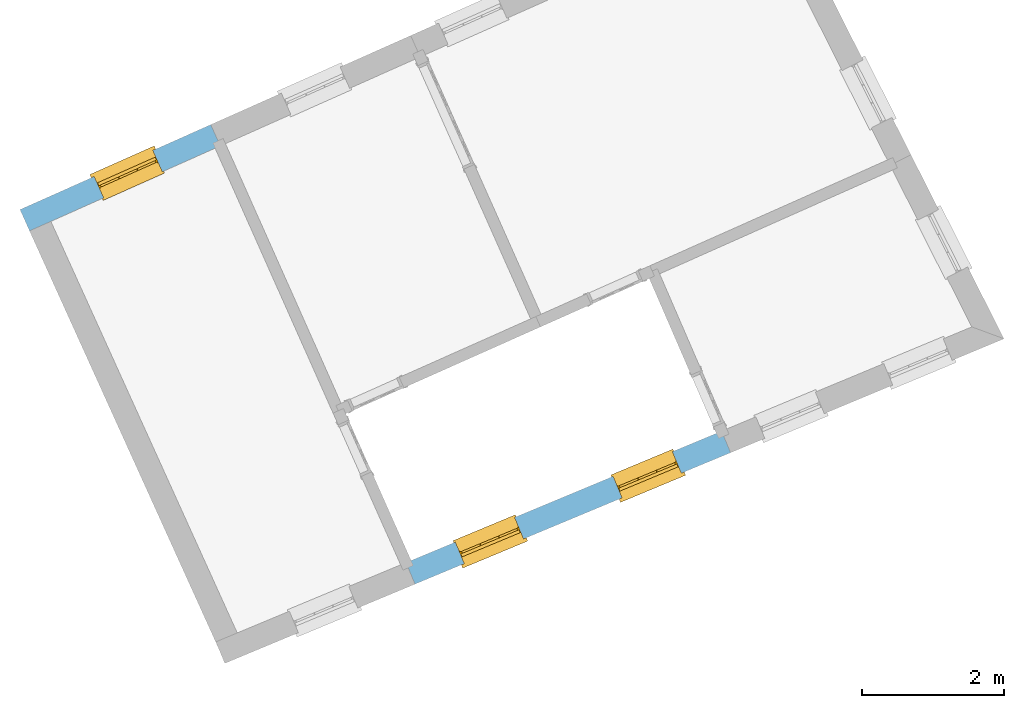
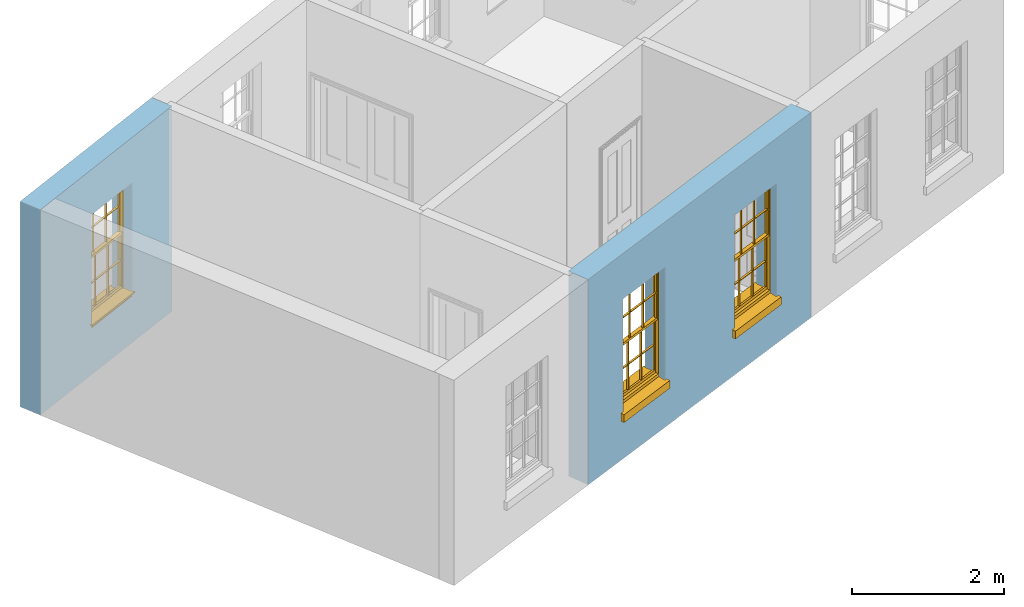
# One storey, part 3 of 8: 3 windows, 3 openings, plus 2 elements that do not belong to this part.
"""IFC2X3 building model written with IfcOpenShell, lengths in metres."""

from ifc_helpers import new_model, si_unit, frame, origin, place, context, subcontext, project, spatial, polyline, outline, extrude, faceted_brep, material, layer, layer_set, layer_usage, element, fill, save


model = new_model("IFC2X3")

# Units and contexts
model_context = context("Model", 3, world=origin())
body_context = subcontext(model_context, "Body", "Model", "MODEL_VIEW")
ifc_project = project(units=[si_unit("PLANEANGLEUNIT", "RADIAN"), si_unit("MASSUNIT", "GRAM", prefix="KILO"), si_unit("FORCEUNIT", "NEWTON", prefix="KILO"), si_unit("LENGTHUNIT", "METRE")], contexts=[model_context])

# Site, building, storey
site_placement = place(None, origin())
site = spatial("IfcSite", under=ifc_project, at=site_placement, CompositionType="ELEMENT")
building_placement = place(None, origin())
building = spatial("IfcBuilding", under=site, at=building_placement, Name="Building plot-1", CompositionType="ELEMENT")
storey_placement = place(None, frame((0.0, 0.0, 5.15)))
storey = spatial("IfcBuildingStorey", under=building, at=storey_placement, Name="Floor 1", CompositionType="ELEMENT", Elevation=5.15)

# Wall, openings, windows
ifc_material = material(Name="Masonry")
ifc_layer = layer(ifc_material, 0.33, ventilated=False)
ifc_layer_set = layer_set([ifc_layer], Name="My Wall")
ifc_layer_usage = layer_usage(ifc_layer_set, "AXIS2", "NEGATIVE", 0.08)
wall_1_placement = place(storey_placement, origin())
wall_1 = element("IfcWallStandardCase", 1, at=wall_1_placement, inside=storey, material=ifc_layer_usage, Name="exterior", context=body_context, shape_type="SweptSolid", body=[
    extrude(outline(polyline([(24.2430798056257, 41.3933128508107), (24.3699915253352, 41.0886927342715), (28.8304515653399, 42.947022580652), (28.7035398456304, 43.2516426971912), (24.2430798056257, 41.3933128508107)])), origin(), (0.0, 0.0, 1.0), 3.3),
])
opening_1_placement = place(storey_placement, frame((0.0, 0.0, 0.75)))
opening_1 = element("IfcOpeningElement", 2, at=opening_1_placement, cuts=wall_1, Name="Opening", ObjectType="Opening", context=body_context, shape_type="SweptSolid", body=[
    extrude(outline(polyline([(25.0651000110172, 41.378290855055), (25.9051130596556, 41.7282595366783), (25.7782013399461, 42.0328796532175), (24.9381882913076, 41.6829109715942), (25.0651000110172, 41.378290855055)])), origin(), (0.0, 0.0, 1.0), 1.82),
])
opening_2_placement = place(storey_placement, frame((0.0, 0.0, 0.75)))
opening_2 = element("IfcOpeningElement", 3, at=opening_2_placement, cuts=wall_1, Name="Opening", ObjectType="Opening", context=body_context, shape_type="SweptSolid", body=[
    extrude(outline(polyline([(27.2953300310195, 42.3074557782452), (28.135343079658, 42.6574244598685), (28.0084313599484, 42.9620445764077), (27.16841831131, 42.6120758947844), (27.2953300310195, 42.3074557782452)])), origin(), (0.0, 0.0, 1.0), 1.82),
])
window_1_placement = place(storey_placement, frame((24.968954768813, 41.609063670615, 0.75), z_axis=(0.0, 0.0, 1.0), x_axis=(0.84001304863844, 0.349968681623302, 0.0)))
window_1 = element("IfcWindow", 4, at=window_1_placement, inside=storey, Name="circulation outside window", OverallHeight=1.82, OverallWidth=0.91, context=body_context, shape_type="Brep", held_by="IfcProductRepresentation", body=[
    faceted_brep([(0.033125, -0.105, 0.975209), (0.01, -0.105, 0.975209), (0.033125, -0.105, 1.376042), (0.876875, -0.105, 0.975209), (0.876875, -0.105, 1.376042), (0.9, -0.105, 0.975209), (0.876875, -0.105, 1.386042), (0.876875, -0.105, 1.786875), (0.9, -0.105, 1.81), (0.033125, -0.105, 1.786875), (0.033125, -0.105, 1.386042), (0.01, -0.105, 1.81), (0.876875, -0.135, 1.376042), (0.876875, -0.135, 0.975209), (0.9, -0.135, 0.937083), (0.033125, -0.135, 1.786875), (0.01, -0.135, 1.81), (0.033125, -0.135, 1.386042), (0.01, -0.135, 0.937083), (0.033125, -0.135, 0.975209), (0.033125, -0.135, 1.376042), (0.876875, -0.135, 1.786875), (0.876875, -0.135, 1.386042), (0.9, -0.135, 1.81), (0.033125, -0.105, 0.937083), (0.01, -0.105, 0.937083), (0.033125, -0.105, 0.53625), (0.876875, -0.105, 0.937083), (0.876875, -0.105, 0.53625), (0.9, -0.105, 0.937083), (0.876875, -0.105, 0.52625), (0.876875, -0.105, 0.125417), (0.9, -0.105, 0.077167), (0.033125, -0.105, 0.125417), (0.033125, -0.105, 0.52625), (0.01, -0.105, 0.077167), (-0.0425, -0.25, 0.01), (-0.0425, -0.3, 0.001667), (0.0, -0.25, 0.01), (0.9525, -0.25, 0.01), (0.91, -0.25, 0.01), (0.9525, -0.3, 0.001667), (-0.02, 0.08, 0.077167), (0.0, 0.08, 0.077167), (-0.02, 0.11, 0.077167), (0.0, -0.06, 0.077167), (0.01, -0.06, 0.077167), (0.91, -0.06, 0.077167), (0.91, 0.08, 0.077167), (0.9, -0.06, 0.077167), (0.93, 0.08, 0.077167), (0.93, 0.11, 0.077167), (0.01, -0.075, 0.975209), (0.9, -0.075, 0.975209), (0.876875, -0.075, 0.125417), (0.876875, -0.075, 0.52625), (0.9, -0.075, 0.077167), (0.876875, -0.075, 0.53625), (0.876875, -0.075, 0.937083), (0.033125, -0.075, 0.125417), (0.01, -0.075, 0.077167), (0.033125, -0.075, 0.52625), (0.033125, -0.075, 0.937083), (0.033125, -0.075, 0.53625), (-0.02, 0.08, 0.052167), (-0.02, 0.11, 0.052167), (0.93, 0.11, 0.052167), (0.93, 0.08, 0.052167), (0.91, 0.08, 0.052167), (0.0, 0.08, 0.052167), (0.91, -0.15, 0.026667), (0.0, -0.15, 0.026667), (-0.0425, -0.3, -0.123333), (0.9525, -0.3, -0.123333), (-0.0425, -0.25, -0.123333), (0.9525, -0.25, -0.123333), (0.01, -0.06, 1.81), (0.9, -0.06, 1.81), (0.0, -0.06, 1.82), (0.91, -0.06, 1.82), (0.01, -0.15, 0.077167), (0.9, -0.15, 0.077167), (0.592292, -0.105, 0.125417), (0.592292, -0.075, 0.125417), (0.317708, -0.075, 0.125417), (0.317708, -0.105, 0.125417), (0.592292, -0.105, 0.53625), (0.317708, -0.105, 0.53625), (0.317708, -0.105, 0.52625), (0.592292, -0.105, 0.52625), (0.592292, -0.075, 0.53625), (0.317708, -0.075, 0.53625), (0.592292, -0.135, 1.386042), (0.592292, -0.105, 1.386042), (0.317708, -0.105, 1.386042), (0.317708, -0.135, 1.386042), (0.317708, -0.135, 1.376042), (0.592292, -0.135, 1.376042), (0.317708, -0.105, 1.376042), (0.592292, -0.105, 1.376042), (0.602292, -0.135, 1.376042), (0.592292, -0.135, 0.975209), (0.602292, -0.135, 0.975209), (0.602292, -0.105, 0.975209), (0.592292, -0.105, 0.975209), (0.602292, -0.105, 1.376042), (0.602292, -0.075, 0.53625), (0.602292, -0.105, 0.53625), (0.317708, -0.075, 0.52625), (0.307708, -0.075, 0.125417), (0.307708, -0.075, 0.52625), (0.602292, -0.075, 0.52625), (0.602292, -0.075, 0.125417), (0.592292, -0.075, 0.52625), (0.307708, -0.075, 0.53625), (0.317708, -0.075, 0.937083), (0.307708, -0.075, 0.937083), (0.602292, -0.075, 0.937083), (0.592292, -0.075, 0.937083), (0.307708, -0.105, 0.52625), (0.307708, -0.105, 0.125417), (0.307708, -0.105, 0.53625), (0.307708, -0.105, 0.937083), (0.592292, -0.105, 0.937083), (0.317708, -0.105, 0.937083), (0.602292, -0.105, 0.937083), (0.602292, -0.105, 0.52625), (0.602292, -0.105, 0.125417), (0.307708, -0.135, 1.386042), (0.307708, -0.135, 1.376042), (0.307708, -0.135, 0.975209), (0.317708, -0.135, 0.975209), (0.317708, -0.135, 1.786875), (0.307708, -0.135, 1.786875), (0.602292, -0.135, 1.786875), (0.592292, -0.135, 1.786875), (0.602292, -0.135, 1.386042), (0.602292, -0.105, 1.386042), (0.307708, -0.105, 1.386042), (0.307708, -0.105, 1.786875), (0.317708, -0.105, 1.786875), (0.592292, -0.105, 1.786875), (0.602292, -0.105, 1.786875), (0.307708, -0.105, 1.376042), (0.317708, -0.105, 0.975209), (0.307708, -0.105, 0.975209), (0.91, -0.15, 1.82), (0.9, -0.15, 1.81), (0.01, -0.15, 1.81), (0.0, -0.15, 1.82), (0.91, -0.25, 0.0), (0.0, -0.25, 0.0), (0.91, 0.08, 0.0), (0.0, 0.08, 0.0)], [[[0, 1, 2]], [[3, 4, 5]], [[6, 7, 8]], [[9, 10, 11]], [[12, 13, 14]], [[15, 16, 17]], [[18, 19, 20]], [[21, 22, 23]], [[24, 25, 26]], [[27, 28, 29]], [[30, 31, 32]], [[33, 34, 35]], [[14, 27, 29]], [[25, 24, 18]], [[36, 37, 38]], [[39, 40, 41]], [[42, 43, 44]], [[45, 46, 43]], [[47, 48, 49]], [[50, 51, 48]], [[1, 0, 52]], [[5, 53, 3]], [[54, 55, 56]], [[57, 58, 53]], [[59, 60, 61]], [[62, 63, 52]], [[48, 43, 46, 49]], [[51, 44, 43, 48]], [[64, 42, 44, 65]], [[65, 44, 51, 66]], [[66, 51, 50, 67]], [[65, 66, 68, 69]], [[60, 56, 49, 46]], [[70, 71, 38, 40]], [[37, 41, 40, 38]], [[37, 72, 73, 41]], [[74, 75, 73, 72]], [[8, 11, 76, 77]], [[76, 78, 79, 77]], [[32, 35, 80, 81]], [[81, 80, 71, 70]], [[82, 83, 84, 85]], [[86, 87, 88, 89]], [[86, 90, 91, 87]], [[92, 93, 94, 95]], [[92, 95, 96, 97]], [[96, 98, 99, 97]], [[100, 97, 101, 102]], [[103, 104, 99, 105]], [[97, 99, 104, 101]], [[102, 103, 105, 100]], [[28, 57, 106, 107]], [[108, 84, 109, 110]], [[111, 112, 83, 113]], [[114, 110, 61, 63]], [[90, 113, 108, 91]], [[115, 91, 114, 116]], [[117, 106, 90, 118]], [[111, 106, 57, 55]], [[119, 110, 109, 120]], [[34, 61, 110, 119]], [[89, 113, 83, 82]], [[88, 108, 113, 89]], [[85, 84, 108, 88]], [[121, 114, 63, 26]], [[122, 116, 114, 121]], [[123, 118, 90, 86]], [[87, 91, 115, 124]], [[107, 106, 117, 125]], [[126, 111, 55, 30]], [[127, 112, 111, 126]], [[126, 30, 28, 107]], [[88, 119, 120, 85]], [[126, 89, 82, 127]], [[125, 123, 86, 107]], [[121, 26, 34, 119]], [[124, 122, 121, 87]], [[128, 17, 20, 129]], [[96, 129, 130, 131]], [[132, 133, 128, 95]], [[134, 135, 92, 136]], [[100, 12, 22, 136]], [[137, 6, 4, 105]], [[94, 138, 139, 140]], [[137, 93, 141, 142]], [[99, 98, 94, 93]], [[143, 2, 10, 138]], [[144, 145, 143, 98]], [[129, 143, 145, 130]], [[20, 2, 143, 129]], [[131, 144, 98, 96]], [[128, 138, 10, 17]], [[133, 139, 138, 128]], [[135, 141, 93, 92]], [[95, 94, 140, 132]], [[22, 6, 137, 136]], [[136, 137, 142, 134]], [[100, 105, 4, 12]], [[107, 86, 89, 126]], [[106, 111, 113, 90]], [[91, 108, 110, 114]], [[87, 121, 119, 88]], [[97, 100, 136, 92]], [[129, 96, 95, 128]], [[98, 143, 138, 94]], [[105, 99, 93, 137]], [[131, 101, 104, 144]], [[124, 115, 118, 123]], [[132, 140, 141, 135]], [[120, 109, 59, 33]], [[15, 9, 139, 133]], [[134, 142, 7, 21]], [[31, 54, 112, 127]], [[36, 74, 72, 37]], [[39, 41, 73, 75]], [[18, 14, 101, 131]], [[23, 16, 132, 135]], [[83, 56, 60, 84]], [[52, 53, 118, 115]], [[53, 52, 144, 104]], [[11, 8, 141, 140]], [[14, 18, 124, 123]], [[2, 1, 11, 10]], [[8, 5, 4, 6]], [[57, 53, 56, 55]], [[60, 52, 63, 61]], [[26, 25, 35, 34]], [[32, 29, 28, 30]], [[14, 23, 22, 12]], [[18, 20, 17, 16]], [[19, 0, 2, 20]], [[17, 10, 9, 15]], [[12, 4, 3, 13]], [[21, 7, 6, 22]], [[27, 58, 57, 28]], [[30, 55, 54, 31]], [[33, 59, 61, 34]], [[26, 63, 62, 24]], [[5, 8, 77, 53]], [[76, 11, 1, 52]], [[46, 45, 78, 76]], [[49, 77, 79, 47]], [[70, 146, 147, 81]], [[71, 80, 148, 149]], [[19, 130, 145, 0]], [[102, 13, 3, 103]], [[116, 122, 24, 62]], [[29, 32, 81, 14]], [[80, 35, 25, 18]], [[60, 46, 76, 52]], [[77, 49, 56, 53]], [[23, 14, 81, 147]], [[16, 148, 80, 18]], [[35, 85, 120]], [[120, 33, 35]], [[127, 82, 32]], [[32, 31, 127]], [[32, 82, 85, 35]], [[102, 101, 14]], [[14, 13, 102]], [[18, 131, 130]], [[130, 19, 18]], [[134, 21, 23]], [[23, 135, 134]], [[16, 15, 133]], [[133, 132, 16]], [[11, 140, 139]], [[139, 9, 11]], [[142, 141, 8]], [[8, 7, 142]], [[23, 147, 148, 16]], [[146, 149, 148, 147]], [[52, 115, 116]], [[116, 62, 52]], [[118, 53, 117]], [[58, 117, 53]], [[27, 125, 117, 58]], [[56, 83, 112]], [[112, 54, 56]], [[109, 84, 60]], [[60, 59, 109]], [[125, 27, 14]], [[14, 123, 125]], [[122, 124, 18]], [[18, 24, 122]], [[145, 144, 52]], [[52, 0, 145]], [[103, 3, 53]], [[53, 104, 103]], [[79, 78, 149, 146]], [[78, 45, 71, 149]], [[146, 70, 47, 79]], [[150, 75, 74, 151]], [[68, 66, 67]], [[48, 68, 67, 50]], [[69, 64, 65]], [[42, 64, 69, 43]], [[69, 68, 152, 153]], [[70, 68, 48, 47]], [[150, 152, 68, 70]], [[43, 69, 71, 45]], [[69, 153, 151, 71]], [[152, 150, 151, 153]], [[38, 151, 74, 36]], [[71, 151, 38]], [[39, 75, 150, 40]], [[40, 150, 70]]]),
])
fill(opening_1, window_1)
window_2_placement = place(storey_placement, frame((27.1991847888153, 42.5382285938052, 0.75), z_axis=(0.0, 0.0, 1.0), x_axis=(0.84001304863844, 0.349968681623302, 0.0)))
window_2 = element("IfcWindow", 5, at=window_2_placement, inside=storey, Name="circulation outside window", OverallHeight=1.82, OverallWidth=0.91, context=body_context, shape_type="Brep", held_by="IfcProductRepresentation", body=[
    faceted_brep([(0.033125, -0.105, 0.975209), (0.01, -0.105, 0.975209), (0.033125, -0.105, 1.376042), (0.876875, -0.105, 0.975209), (0.876875, -0.105, 1.376042), (0.9, -0.105, 0.975209), (0.876875, -0.105, 1.386042), (0.876875, -0.105, 1.786875), (0.9, -0.105, 1.81), (0.033125, -0.105, 1.786875), (0.033125, -0.105, 1.386042), (0.01, -0.105, 1.81), (0.876875, -0.135, 1.376042), (0.876875, -0.135, 0.975209), (0.9, -0.135, 0.937083), (0.033125, -0.135, 1.786875), (0.01, -0.135, 1.81), (0.033125, -0.135, 1.386042), (0.01, -0.135, 0.937083), (0.033125, -0.135, 0.975209), (0.033125, -0.135, 1.376042), (0.876875, -0.135, 1.786875), (0.876875, -0.135, 1.386042), (0.9, -0.135, 1.81), (0.033125, -0.105, 0.937083), (0.01, -0.105, 0.937083), (0.033125, -0.105, 0.53625), (0.876875, -0.105, 0.937083), (0.876875, -0.105, 0.53625), (0.9, -0.105, 0.937083), (0.876875, -0.105, 0.52625), (0.876875, -0.105, 0.125417), (0.9, -0.105, 0.077167), (0.033125, -0.105, 0.125417), (0.033125, -0.105, 0.52625), (0.01, -0.105, 0.077167), (-0.0425, -0.25, 0.01), (-0.0425, -0.3, 0.001667), (0.0, -0.25, 0.01), (0.9525, -0.25, 0.01), (0.91, -0.25, 0.01), (0.9525, -0.3, 0.001667), (-0.02, 0.08, 0.077167), (0.0, 0.08, 0.077167), (-0.02, 0.11, 0.077167), (0.0, -0.06, 0.077167), (0.01, -0.06, 0.077167), (0.91, -0.06, 0.077167), (0.91, 0.08, 0.077167), (0.9, -0.06, 0.077167), (0.93, 0.08, 0.077167), (0.93, 0.11, 0.077167), (0.01, -0.075, 0.975209), (0.9, -0.075, 0.975209), (0.876875, -0.075, 0.125417), (0.876875, -0.075, 0.52625), (0.9, -0.075, 0.077167), (0.876875, -0.075, 0.53625), (0.876875, -0.075, 0.937083), (0.033125, -0.075, 0.125417), (0.01, -0.075, 0.077167), (0.033125, -0.075, 0.52625), (0.033125, -0.075, 0.937083), (0.033125, -0.075, 0.53625), (-0.02, 0.08, 0.052167), (-0.02, 0.11, 0.052167), (0.93, 0.11, 0.052167), (0.93, 0.08, 0.052167), (0.91, 0.08, 0.052167), (0.0, 0.08, 0.052167), (0.91, -0.15, 0.026667), (0.0, -0.15, 0.026667), (-0.0425, -0.3, -0.123333), (0.9525, -0.3, -0.123333), (-0.0425, -0.25, -0.123333), (0.9525, -0.25, -0.123333), (0.01, -0.06, 1.81), (0.9, -0.06, 1.81), (0.0, -0.06, 1.82), (0.91, -0.06, 1.82), (0.01, -0.15, 0.077167), (0.9, -0.15, 0.077167), (0.592292, -0.105, 0.125417), (0.592292, -0.075, 0.125417), (0.317708, -0.075, 0.125417), (0.317708, -0.105, 0.125417), (0.592292, -0.105, 0.53625), (0.317708, -0.105, 0.53625), (0.317708, -0.105, 0.52625), (0.592292, -0.105, 0.52625), (0.592292, -0.075, 0.53625), (0.317708, -0.075, 0.53625), (0.592292, -0.135, 1.386042), (0.592292, -0.105, 1.386042), (0.317708, -0.105, 1.386042), (0.317708, -0.135, 1.386042), (0.317708, -0.135, 1.376042), (0.592292, -0.135, 1.376042), (0.317708, -0.105, 1.376042), (0.592292, -0.105, 1.376042), (0.602292, -0.135, 1.376042), (0.592292, -0.135, 0.975209), (0.602292, -0.135, 0.975209), (0.602292, -0.105, 0.975209), (0.592292, -0.105, 0.975209), (0.602292, -0.105, 1.376042), (0.602292, -0.075, 0.53625), (0.602292, -0.105, 0.53625), (0.317708, -0.075, 0.52625), (0.307708, -0.075, 0.125417), (0.307708, -0.075, 0.52625), (0.602292, -0.075, 0.52625), (0.602292, -0.075, 0.125417), (0.592292, -0.075, 0.52625), (0.307708, -0.075, 0.53625), (0.317708, -0.075, 0.937083), (0.307708, -0.075, 0.937083), (0.602292, -0.075, 0.937083), (0.592292, -0.075, 0.937083), (0.307708, -0.105, 0.52625), (0.307708, -0.105, 0.125417), (0.307708, -0.105, 0.53625), (0.307708, -0.105, 0.937083), (0.592292, -0.105, 0.937083), (0.317708, -0.105, 0.937083), (0.602292, -0.105, 0.937083), (0.602292, -0.105, 0.52625), (0.602292, -0.105, 0.125417), (0.307708, -0.135, 1.386042), (0.307708, -0.135, 1.376042), (0.307708, -0.135, 0.975209), (0.317708, -0.135, 0.975209), (0.317708, -0.135, 1.786875), (0.307708, -0.135, 1.786875), (0.602292, -0.135, 1.786875), (0.592292, -0.135, 1.786875), (0.602292, -0.135, 1.386042), (0.602292, -0.105, 1.386042), (0.307708, -0.105, 1.386042), (0.307708, -0.105, 1.786875), (0.317708, -0.105, 1.786875), (0.592292, -0.105, 1.786875), (0.602292, -0.105, 1.786875), (0.307708, -0.105, 1.376042), (0.317708, -0.105, 0.975209), (0.307708, -0.105, 0.975209), (0.91, -0.15, 1.82), (0.9, -0.15, 1.81), (0.01, -0.15, 1.81), (0.0, -0.15, 1.82), (0.91, -0.25, 0.0), (0.0, -0.25, 0.0), (0.91, 0.08, 0.0), (0.0, 0.08, 0.0)], [[[0, 1, 2]], [[3, 4, 5]], [[6, 7, 8]], [[9, 10, 11]], [[12, 13, 14]], [[15, 16, 17]], [[18, 19, 20]], [[21, 22, 23]], [[24, 25, 26]], [[27, 28, 29]], [[30, 31, 32]], [[33, 34, 35]], [[14, 27, 29]], [[25, 24, 18]], [[36, 37, 38]], [[39, 40, 41]], [[42, 43, 44]], [[45, 46, 43]], [[47, 48, 49]], [[50, 51, 48]], [[1, 0, 52]], [[5, 53, 3]], [[54, 55, 56]], [[57, 58, 53]], [[59, 60, 61]], [[62, 63, 52]], [[48, 43, 46, 49]], [[51, 44, 43, 48]], [[64, 42, 44, 65]], [[65, 44, 51, 66]], [[66, 51, 50, 67]], [[65, 66, 68, 69]], [[60, 56, 49, 46]], [[70, 71, 38, 40]], [[37, 41, 40, 38]], [[37, 72, 73, 41]], [[74, 75, 73, 72]], [[8, 11, 76, 77]], [[76, 78, 79, 77]], [[32, 35, 80, 81]], [[81, 80, 71, 70]], [[82, 83, 84, 85]], [[86, 87, 88, 89]], [[86, 90, 91, 87]], [[92, 93, 94, 95]], [[92, 95, 96, 97]], [[96, 98, 99, 97]], [[100, 97, 101, 102]], [[103, 104, 99, 105]], [[97, 99, 104, 101]], [[102, 103, 105, 100]], [[28, 57, 106, 107]], [[108, 84, 109, 110]], [[111, 112, 83, 113]], [[114, 110, 61, 63]], [[90, 113, 108, 91]], [[115, 91, 114, 116]], [[117, 106, 90, 118]], [[111, 106, 57, 55]], [[119, 110, 109, 120]], [[34, 61, 110, 119]], [[89, 113, 83, 82]], [[88, 108, 113, 89]], [[85, 84, 108, 88]], [[121, 114, 63, 26]], [[122, 116, 114, 121]], [[123, 118, 90, 86]], [[87, 91, 115, 124]], [[107, 106, 117, 125]], [[126, 111, 55, 30]], [[127, 112, 111, 126]], [[126, 30, 28, 107]], [[88, 119, 120, 85]], [[126, 89, 82, 127]], [[125, 123, 86, 107]], [[121, 26, 34, 119]], [[124, 122, 121, 87]], [[128, 17, 20, 129]], [[96, 129, 130, 131]], [[132, 133, 128, 95]], [[134, 135, 92, 136]], [[100, 12, 22, 136]], [[137, 6, 4, 105]], [[94, 138, 139, 140]], [[137, 93, 141, 142]], [[99, 98, 94, 93]], [[143, 2, 10, 138]], [[144, 145, 143, 98]], [[129, 143, 145, 130]], [[20, 2, 143, 129]], [[131, 144, 98, 96]], [[128, 138, 10, 17]], [[133, 139, 138, 128]], [[135, 141, 93, 92]], [[95, 94, 140, 132]], [[22, 6, 137, 136]], [[136, 137, 142, 134]], [[100, 105, 4, 12]], [[107, 86, 89, 126]], [[106, 111, 113, 90]], [[91, 108, 110, 114]], [[87, 121, 119, 88]], [[97, 100, 136, 92]], [[129, 96, 95, 128]], [[98, 143, 138, 94]], [[105, 99, 93, 137]], [[131, 101, 104, 144]], [[124, 115, 118, 123]], [[132, 140, 141, 135]], [[120, 109, 59, 33]], [[15, 9, 139, 133]], [[134, 142, 7, 21]], [[31, 54, 112, 127]], [[36, 74, 72, 37]], [[39, 41, 73, 75]], [[18, 14, 101, 131]], [[23, 16, 132, 135]], [[83, 56, 60, 84]], [[52, 53, 118, 115]], [[53, 52, 144, 104]], [[11, 8, 141, 140]], [[14, 18, 124, 123]], [[2, 1, 11, 10]], [[8, 5, 4, 6]], [[57, 53, 56, 55]], [[60, 52, 63, 61]], [[26, 25, 35, 34]], [[32, 29, 28, 30]], [[14, 23, 22, 12]], [[18, 20, 17, 16]], [[19, 0, 2, 20]], [[17, 10, 9, 15]], [[12, 4, 3, 13]], [[21, 7, 6, 22]], [[27, 58, 57, 28]], [[30, 55, 54, 31]], [[33, 59, 61, 34]], [[26, 63, 62, 24]], [[5, 8, 77, 53]], [[76, 11, 1, 52]], [[46, 45, 78, 76]], [[49, 77, 79, 47]], [[70, 146, 147, 81]], [[71, 80, 148, 149]], [[19, 130, 145, 0]], [[102, 13, 3, 103]], [[116, 122, 24, 62]], [[29, 32, 81, 14]], [[80, 35, 25, 18]], [[60, 46, 76, 52]], [[77, 49, 56, 53]], [[23, 14, 81, 147]], [[16, 148, 80, 18]], [[35, 85, 120]], [[120, 33, 35]], [[127, 82, 32]], [[32, 31, 127]], [[32, 82, 85, 35]], [[102, 101, 14]], [[14, 13, 102]], [[18, 131, 130]], [[130, 19, 18]], [[134, 21, 23]], [[23, 135, 134]], [[16, 15, 133]], [[133, 132, 16]], [[11, 140, 139]], [[139, 9, 11]], [[142, 141, 8]], [[8, 7, 142]], [[23, 147, 148, 16]], [[146, 149, 148, 147]], [[52, 115, 116]], [[116, 62, 52]], [[118, 53, 117]], [[58, 117, 53]], [[27, 125, 117, 58]], [[56, 83, 112]], [[112, 54, 56]], [[109, 84, 60]], [[60, 59, 109]], [[125, 27, 14]], [[14, 123, 125]], [[122, 124, 18]], [[18, 24, 122]], [[145, 144, 52]], [[52, 0, 145]], [[103, 3, 53]], [[53, 104, 103]], [[79, 78, 149, 146]], [[78, 45, 71, 149]], [[146, 70, 47, 79]], [[150, 75, 74, 151]], [[68, 66, 67]], [[48, 68, 67, 50]], [[69, 64, 65]], [[42, 64, 69, 43]], [[69, 68, 152, 153]], [[70, 68, 48, 47]], [[150, 152, 68, 70]], [[43, 69, 71, 45]], [[69, 153, 151, 71]], [[152, 150, 151, 153]], [[38, 151, 74, 36]], [[71, 151, 38]], [[39, 75, 150, 40]], [[40, 150, 70]]]),
])
fill(opening_2, window_2)

# Wall, opening, window
wall_2_placement = place(storey_placement, origin())
wall_2 = element("IfcWallStandardCase", 6, at=wall_2_placement, inside=storey, material=ifc_layer_usage, Name="exterior", context=body_context, shape_type="SweptSolid", body=[
    extrude(outline(polyline([(21.6184925194357, 47.2817904729088), (21.4842375416494, 47.5832462755393), (18.7880965575994, 46.3825052555824), (18.9223515353857, 46.0810494529519), (21.6184925194357, 47.2817904729088)])), origin(), (0.0, 0.0, 1.0), 3.3),
])
opening_3_placement = place(storey_placement, frame((0.0, 0.0, 0.75)))
opening_3 = element("IfcOpeningElement", 7, at=opening_3_placement, cuts=wall_2, Name="Opening", ObjectType="Opening", context=body_context, shape_type="SweptSolid", body=[
    extrude(outline(polyline([(20.6659984603083, 47.218839059852), (19.8347112469939, 46.8486207877745), (19.9689662247802, 46.547164985144), (20.8002534380946, 46.9173832572215), (20.6659984603083, 47.218839059852)])), origin(), (0.0, 0.0, 1.0), 1.82),
])
window_3_placement = place(storey_placement, frame((20.7677067768131, 46.9904634517986, 0.75), z_axis=(0.0, 0.0, 1.0), x_axis=(-0.831287213314376, -0.370218272077466, 0.0)))
window_3 = element("IfcWindow", 8, at=window_3_placement, inside=storey, Name="bedroom outside window", OverallHeight=1.82, OverallWidth=0.91, context=body_context, shape_type="Brep", held_by="IfcProductRepresentation", body=[
    faceted_brep([(0.033125, -0.105, 0.975209), (0.01, -0.105, 0.975209), (0.033125, -0.105, 1.376042), (0.876875, -0.105, 0.975209), (0.876875, -0.105, 1.376042), (0.9, -0.105, 0.975209), (0.876875, -0.105, 1.386042), (0.876875, -0.105, 1.786875), (0.9, -0.105, 1.81), (0.033125, -0.105, 1.786875), (0.033125, -0.105, 1.386042), (0.01, -0.105, 1.81), (0.876875, -0.135, 1.376042), (0.876875, -0.135, 0.975209), (0.9, -0.135, 0.937083), (0.033125, -0.135, 1.786875), (0.01, -0.135, 1.81), (0.033125, -0.135, 1.386042), (0.01, -0.135, 0.937083), (0.033125, -0.135, 0.975209), (0.033125, -0.135, 1.376042), (0.876875, -0.135, 1.786875), (0.876875, -0.135, 1.386042), (0.9, -0.135, 1.81), (0.033125, -0.105, 0.937083), (0.01, -0.105, 0.937083), (0.033125, -0.105, 0.53625), (0.876875, -0.105, 0.937083), (0.876875, -0.105, 0.53625), (0.9, -0.105, 0.937083), (0.876875, -0.105, 0.52625), (0.876875, -0.105, 0.125417), (0.9, -0.105, 0.077167), (0.033125, -0.105, 0.125417), (0.033125, -0.105, 0.52625), (0.01, -0.105, 0.077167), (-0.0425, -0.25, 0.01), (-0.0425, -0.3, 0.001667), (0.0, -0.25, 0.01), (0.9525, -0.25, 0.01), (0.91, -0.25, 0.01), (0.9525, -0.3, 0.001667), (-0.02, 0.08, 0.077167), (0.0, 0.08, 0.077167), (-0.02, 0.11, 0.077167), (0.0, -0.06, 0.077167), (0.01, -0.06, 0.077167), (0.91, -0.06, 0.077167), (0.91, 0.08, 0.077167), (0.9, -0.06, 0.077167), (0.93, 0.08, 0.077167), (0.93, 0.11, 0.077167), (0.01, -0.075, 0.975209), (0.9, -0.075, 0.975209), (0.876875, -0.075, 0.125417), (0.876875, -0.075, 0.52625), (0.9, -0.075, 0.077167), (0.876875, -0.075, 0.53625), (0.876875, -0.075, 0.937083), (0.033125, -0.075, 0.125417), (0.01, -0.075, 0.077167), (0.033125, -0.075, 0.52625), (0.033125, -0.075, 0.937083), (0.033125, -0.075, 0.53625), (-0.02, 0.08, 0.052167), (-0.02, 0.11, 0.052167), (0.93, 0.11, 0.052167), (0.93, 0.08, 0.052167), (0.91, 0.08, 0.052167), (0.0, 0.08, 0.052167), (0.91, -0.15, 0.026667), (0.0, -0.15, 0.026667), (-0.0425, -0.3, -0.123333), (0.9525, -0.3, -0.123333), (-0.0425, -0.25, -0.123333), (0.9525, -0.25, -0.123333), (0.01, -0.06, 1.81), (0.9, -0.06, 1.81), (0.0, -0.06, 1.82), (0.91, -0.06, 1.82), (0.01, -0.15, 0.077167), (0.9, -0.15, 0.077167), (0.592292, -0.105, 0.125417), (0.592292, -0.075, 0.125417), (0.317708, -0.075, 0.125417), (0.317708, -0.105, 0.125417), (0.592292, -0.105, 0.53625), (0.317708, -0.105, 0.53625), (0.317708, -0.105, 0.52625), (0.592292, -0.105, 0.52625), (0.592292, -0.075, 0.53625), (0.317708, -0.075, 0.53625), (0.592292, -0.135, 1.386042), (0.592292, -0.105, 1.386042), (0.317708, -0.105, 1.386042), (0.317708, -0.135, 1.386042), (0.317708, -0.135, 1.376042), (0.592292, -0.135, 1.376042), (0.317708, -0.105, 1.376042), (0.592292, -0.105, 1.376042), (0.602292, -0.135, 1.376042), (0.592292, -0.135, 0.975209), (0.602292, -0.135, 0.975209), (0.602292, -0.105, 0.975209), (0.592292, -0.105, 0.975209), (0.602292, -0.105, 1.376042), (0.602292, -0.075, 0.53625), (0.602292, -0.105, 0.53625), (0.317708, -0.075, 0.52625), (0.307708, -0.075, 0.125417), (0.307708, -0.075, 0.52625), (0.602292, -0.075, 0.52625), (0.602292, -0.075, 0.125417), (0.592292, -0.075, 0.52625), (0.307708, -0.075, 0.53625), (0.317708, -0.075, 0.937083), (0.307708, -0.075, 0.937083), (0.602292, -0.075, 0.937083), (0.592292, -0.075, 0.937083), (0.307708, -0.105, 0.52625), (0.307708, -0.105, 0.125417), (0.307708, -0.105, 0.53625), (0.307708, -0.105, 0.937083), (0.592292, -0.105, 0.937083), (0.317708, -0.105, 0.937083), (0.602292, -0.105, 0.937083), (0.602292, -0.105, 0.52625), (0.602292, -0.105, 0.125417), (0.307708, -0.135, 1.386042), (0.307708, -0.135, 1.376042), (0.307708, -0.135, 0.975209), (0.317708, -0.135, 0.975209), (0.317708, -0.135, 1.786875), (0.307708, -0.135, 1.786875), (0.602292, -0.135, 1.786875), (0.592292, -0.135, 1.786875), (0.602292, -0.135, 1.386042), (0.602292, -0.105, 1.386042), (0.307708, -0.105, 1.386042), (0.307708, -0.105, 1.786875), (0.317708, -0.105, 1.786875), (0.592292, -0.105, 1.786875), (0.602292, -0.105, 1.786875), (0.307708, -0.105, 1.376042), (0.317708, -0.105, 0.975209), (0.307708, -0.105, 0.975209), (0.91, -0.15, 1.82), (0.9, -0.15, 1.81), (0.01, -0.15, 1.81), (0.0, -0.15, 1.82), (0.91, -0.25, 0.0), (0.0, -0.25, 0.0), (0.91, 0.08, 0.0), (0.0, 0.08, 0.0)], [[[0, 1, 2]], [[3, 4, 5]], [[6, 7, 8]], [[9, 10, 11]], [[12, 13, 14]], [[15, 16, 17]], [[18, 19, 20]], [[21, 22, 23]], [[24, 25, 26]], [[27, 28, 29]], [[30, 31, 32]], [[33, 34, 35]], [[14, 27, 29]], [[25, 24, 18]], [[36, 37, 38]], [[39, 40, 41]], [[42, 43, 44]], [[45, 46, 43]], [[47, 48, 49]], [[50, 51, 48]], [[1, 0, 52]], [[5, 53, 3]], [[54, 55, 56]], [[57, 58, 53]], [[59, 60, 61]], [[62, 63, 52]], [[48, 43, 46, 49]], [[51, 44, 43, 48]], [[64, 42, 44, 65]], [[65, 44, 51, 66]], [[66, 51, 50, 67]], [[65, 66, 68, 69]], [[60, 56, 49, 46]], [[70, 71, 38, 40]], [[37, 41, 40, 38]], [[37, 72, 73, 41]], [[74, 75, 73, 72]], [[8, 11, 76, 77]], [[76, 78, 79, 77]], [[32, 35, 80, 81]], [[81, 80, 71, 70]], [[82, 83, 84, 85]], [[86, 87, 88, 89]], [[86, 90, 91, 87]], [[92, 93, 94, 95]], [[92, 95, 96, 97]], [[96, 98, 99, 97]], [[100, 97, 101, 102]], [[103, 104, 99, 105]], [[97, 99, 104, 101]], [[102, 103, 105, 100]], [[28, 57, 106, 107]], [[108, 84, 109, 110]], [[111, 112, 83, 113]], [[114, 110, 61, 63]], [[90, 113, 108, 91]], [[115, 91, 114, 116]], [[117, 106, 90, 118]], [[111, 106, 57, 55]], [[119, 110, 109, 120]], [[34, 61, 110, 119]], [[89, 113, 83, 82]], [[88, 108, 113, 89]], [[85, 84, 108, 88]], [[121, 114, 63, 26]], [[122, 116, 114, 121]], [[123, 118, 90, 86]], [[87, 91, 115, 124]], [[107, 106, 117, 125]], [[126, 111, 55, 30]], [[127, 112, 111, 126]], [[126, 30, 28, 107]], [[88, 119, 120, 85]], [[126, 89, 82, 127]], [[125, 123, 86, 107]], [[121, 26, 34, 119]], [[124, 122, 121, 87]], [[128, 17, 20, 129]], [[96, 129, 130, 131]], [[132, 133, 128, 95]], [[134, 135, 92, 136]], [[100, 12, 22, 136]], [[137, 6, 4, 105]], [[94, 138, 139, 140]], [[137, 93, 141, 142]], [[99, 98, 94, 93]], [[143, 2, 10, 138]], [[144, 145, 143, 98]], [[129, 143, 145, 130]], [[20, 2, 143, 129]], [[131, 144, 98, 96]], [[128, 138, 10, 17]], [[133, 139, 138, 128]], [[135, 141, 93, 92]], [[95, 94, 140, 132]], [[22, 6, 137, 136]], [[136, 137, 142, 134]], [[100, 105, 4, 12]], [[107, 86, 89, 126]], [[106, 111, 113, 90]], [[91, 108, 110, 114]], [[87, 121, 119, 88]], [[97, 100, 136, 92]], [[129, 96, 95, 128]], [[98, 143, 138, 94]], [[105, 99, 93, 137]], [[131, 101, 104, 144]], [[124, 115, 118, 123]], [[132, 140, 141, 135]], [[120, 109, 59, 33]], [[15, 9, 139, 133]], [[134, 142, 7, 21]], [[31, 54, 112, 127]], [[36, 74, 72, 37]], [[39, 41, 73, 75]], [[18, 14, 101, 131]], [[23, 16, 132, 135]], [[83, 56, 60, 84]], [[52, 53, 118, 115]], [[53, 52, 144, 104]], [[11, 8, 141, 140]], [[14, 18, 124, 123]], [[2, 1, 11, 10]], [[8, 5, 4, 6]], [[57, 53, 56, 55]], [[60, 52, 63, 61]], [[26, 25, 35, 34]], [[32, 29, 28, 30]], [[14, 23, 22, 12]], [[18, 20, 17, 16]], [[19, 0, 2, 20]], [[17, 10, 9, 15]], [[12, 4, 3, 13]], [[21, 7, 6, 22]], [[27, 58, 57, 28]], [[30, 55, 54, 31]], [[33, 59, 61, 34]], [[26, 63, 62, 24]], [[5, 8, 77, 53]], [[76, 11, 1, 52]], [[46, 45, 78, 76]], [[49, 77, 79, 47]], [[70, 146, 147, 81]], [[71, 80, 148, 149]], [[19, 130, 145, 0]], [[102, 13, 3, 103]], [[116, 122, 24, 62]], [[29, 32, 81, 14]], [[80, 35, 25, 18]], [[60, 46, 76, 52]], [[77, 49, 56, 53]], [[23, 14, 81, 147]], [[16, 148, 80, 18]], [[35, 85, 120]], [[120, 33, 35]], [[127, 82, 32]], [[32, 31, 127]], [[32, 82, 85, 35]], [[102, 101, 14]], [[14, 13, 102]], [[18, 131, 130]], [[130, 19, 18]], [[134, 21, 23]], [[23, 135, 134]], [[16, 15, 133]], [[133, 132, 16]], [[11, 140, 139]], [[139, 9, 11]], [[142, 141, 8]], [[8, 7, 142]], [[23, 147, 148, 16]], [[146, 149, 148, 147]], [[52, 115, 116]], [[116, 62, 52]], [[118, 53, 117]], [[58, 117, 53]], [[27, 125, 117, 58]], [[56, 83, 112]], [[112, 54, 56]], [[109, 84, 60]], [[60, 59, 109]], [[125, 27, 14]], [[14, 123, 125]], [[122, 124, 18]], [[18, 24, 122]], [[145, 144, 52]], [[52, 0, 145]], [[103, 3, 53]], [[53, 104, 103]], [[79, 78, 149, 146]], [[78, 45, 71, 149]], [[146, 70, 47, 79]], [[150, 75, 74, 151]], [[68, 66, 67]], [[48, 68, 67, 50]], [[69, 64, 65]], [[42, 64, 69, 43]], [[69, 68, 152, 153]], [[70, 68, 48, 47]], [[150, 152, 68, 70]], [[43, 69, 71, 45]], [[69, 153, 151, 71]], [[152, 150, 151, 153]], [[38, 151, 74, 36]], [[71, 151, 38]], [[39, 75, 150, 40]], [[40, 150, 70]]]),
])
fill(opening_3, window_3)

save(model, "model.ifc")
